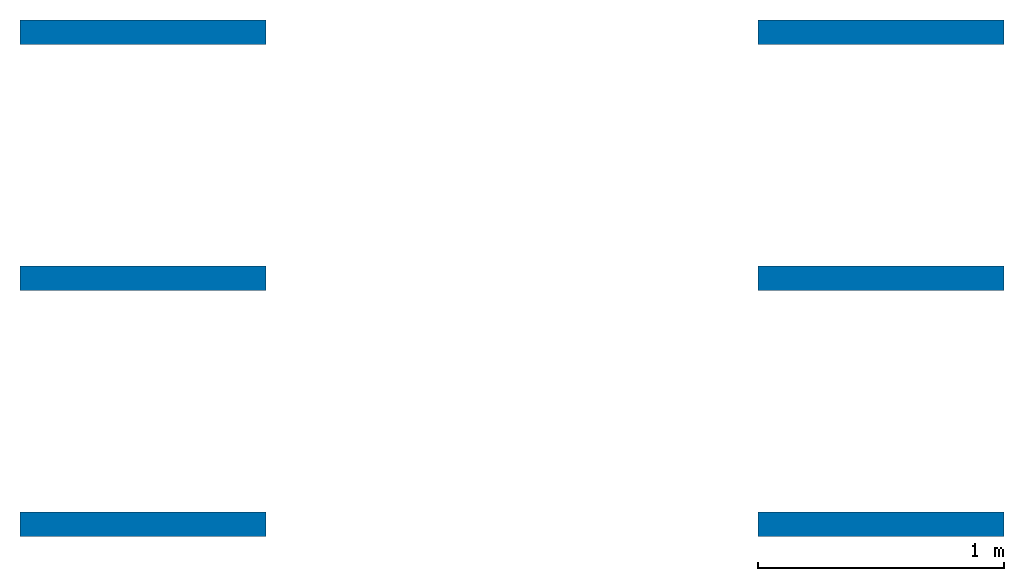
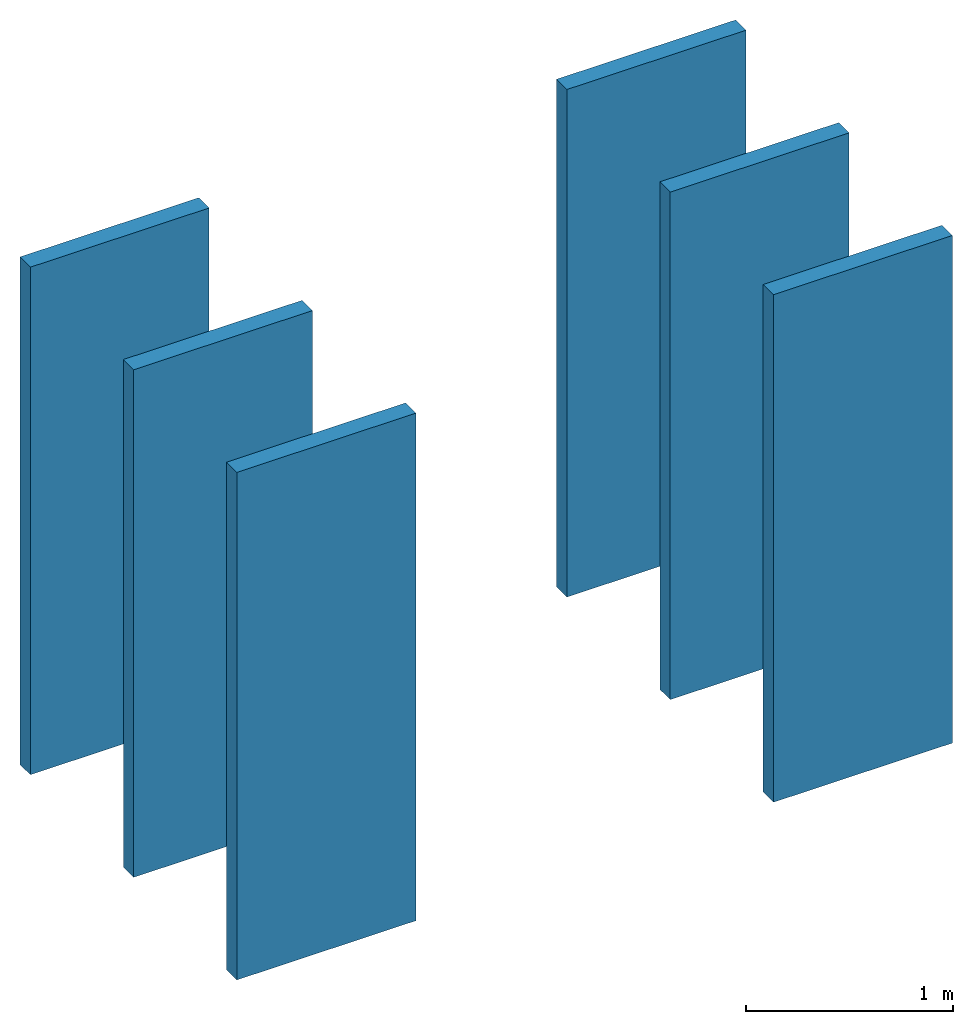
# One storey: 6 walls.
"""IFC4 building model written with IfcOpenShell, lengths in metres."""

import ifcopenshell
import ifcopenshell.guid

model = None  # the IFC model being written
_history = None  # IfcOwnerHistory: only IFC2X3 demands one
_inside = {}  # id of a spatial element -> (the spatial element, [elements in it])
_under = {}  # id of a project, library or spatial element -> (it, [spatial elements below it])
_declared = {}  # id of a project -> (the project, [libraries it declares])
_typed = {}  # id of a type object -> (the type object, [elements of that type])
_made_of = {}  # id of a material, layer set ... -> (it, [elements and type objects made of it])


def new_model(schema):
    """Start an empty IFC model of exactly this schema.

    Asked for "IFC4X3", IfcOpenShell would pick the latest addendum, in which some entities
    have other attributes; the version numbers below select the first issue.
    IFC2X3 requires an IfcOwnerHistory on every rooted entity: one is made here for all.
    """
    global model, _history
    if schema == "IFC4X3":
        model = ifcopenshell.file(schema_version=(4, 3, 0, 0))
    else:
        model = ifcopenshell.file(schema=schema)
    _inside.clear()
    _under.clear()
    _declared.clear()
    _typed.clear()
    _made_of.clear()
    _history = None
    if model.schema == "IFC2X3":
        org = make("IfcOrganization", Name="unknown")
        user = make(
            "IfcPersonAndOrganization",
            ThePerson=make("IfcPerson", FamilyName="unknown"),
            TheOrganization=org,
        )
        app = make(
            "IfcApplication",
            ApplicationDeveloper=org,
            Version="unknown",
            ApplicationFullName="unknown",
            ApplicationIdentifier="unknown",
        )
        _history = make(
            "IfcOwnerHistory",
            OwningUser=user,
            OwningApplication=app,
            ChangeAction="ADDED",
            CreationDate=0,
        )
    return model


def make(cls, **values):
    """One entity of the class cls with the attributes given. An attribute that is None is left unset."""
    return model.create_entity(
        cls, **{name: value for name, value in values.items() if value is not None}
    )


def entity(cls, *values):
    """Any entity or typed value of the class cls, its attributes in the order of the schema. None: left unset."""
    e = model.create_entity(cls)
    for i, value in enumerate(values):
        if value is not None:
            e[i] = value
    return e


def rooted(cls, **values):
    """An entity with a GlobalId (a new one), such as an element, a storey or a relation."""
    return make(cls, GlobalId=ifcopenshell.guid.new(), OwnerHistory=_history, **values)


def si_unit(unit_type, name, prefix=None):
    """IfcSIUnit, for example si_unit("LENGTHUNIT", "METRE", prefix="MILLI")."""
    return make("IfcSIUnit", UnitType=unit_type, Prefix=prefix, Name=name)


def converted_unit(unit_type, name, factor, base, dimensions=None, offset=None):
    """IfcConversionBasedUnit, such as the inch: factor (a typed value) times the base unit."""
    return make(
        "IfcConversionBasedUnit"
        if offset is None
        else "IfcConversionBasedUnitWithOffset",
        ConversionOffset=offset,
        Dimensions=None
        if dimensions is None
        else entity("IfcDimensionalExponents", *dimensions),
        UnitType=unit_type,
        Name=name,
        ConversionFactor=make(
            "IfcMeasureWithUnit", ValueComponent=factor, UnitComponent=base
        ),
    )


def assignment(units):
    """IfcUnitAssignment: the units of a project."""
    return None if units is None else make("IfcUnitAssignment", Units=units)


def point(xyz):
    """IfcCartesianPoint."""
    return None if xyz is None else make("IfcCartesianPoint", Coordinates=xyz)


def direction(xyz):
    """IfcDirection."""
    return None if xyz is None else make("IfcDirection", DirectionRatios=xyz)


def frame(location, z_axis=None, x_axis=None):
    """IfcAxis2Placement3D, a coordinate frame: its origin and axes. An axis left out is left unset."""
    return make(
        "IfcAxis2Placement3D",
        Location=point(location),
        Axis=direction(z_axis),
        RefDirection=direction(x_axis),
    )


def frame_2d(location, x_axis=None):
    """IfcAxis2Placement2D, a coordinate frame in the plane: its origin and x axis."""
    return make(
        "IfcAxis2Placement2D", Location=point(location), RefDirection=direction(x_axis)
    )


def origin_with_axes():
    """The frame at (0, 0, 0) with the z axis (0, 0, 1) and the x axis (1, 0, 0) written out."""
    return frame((0.0, 0.0, 0.0), z_axis=(0.0, 0.0, 1.0), x_axis=(1.0, 0.0, 0.0))


def origin_2d_with_axis():
    """The frame at (0, 0) in the plane with the x axis (1, 0) written out."""
    return frame_2d((0.0, 0.0), x_axis=(1.0, 0.0))


def place(relative_to, where):
    """IfcLocalPlacement: puts the frame where relative to a parent placement (None: the world)."""
    return make(
        "IfcLocalPlacement", PlacementRelTo=relative_to, RelativePlacement=where
    )


def context(
    kind, dimensions, precision=None, world=None, true_north=None, identifier=None
):
    """IfcGeometricRepresentationContext, for example the 3D "Model" context."""
    return make(
        "IfcGeometricRepresentationContext",
        ContextIdentifier=identifier,
        ContextType=kind,
        CoordinateSpaceDimension=dimensions,
        Precision=precision,
        WorldCoordinateSystem=world,
        TrueNorth=true_north,
    )


def subcontext(parent, identifier, kind, view, scale=None):
    """IfcGeometricRepresentationSubContext, for example "Body" below "Model"."""
    return make(
        "IfcGeometricRepresentationSubContext",
        ContextIdentifier=identifier,
        ContextType=kind,
        ParentContext=parent,
        TargetScale=scale,
        TargetView=view,
    )


def project(units=None, contexts=None):
    """IfcProject with its units and contexts."""
    return rooted(
        "IfcProject",
        Name="project",
        RepresentationContexts=contexts,
        UnitsInContext=assignment(units),
    )


def spatial(cls, under=None, at=None, **own):
    """A site, building, storey or space (cls), placed at a placement, below another one or the project."""
    s = rooted(cls, ObjectPlacement=at, **own)
    if under is not None:
        _under.setdefault(under.id(), (under, []))[1].append(s)
    return s


def point_list(points):
    """IfcCartesianPointList2D or 3D."""
    cls = (
        "IfcCartesianPointList2D" if len(points[0]) == 2 else "IfcCartesianPointList3D"
    )
    return make(cls, CoordList=points)


def indexed_curve(points, segments=None, self_intersect=None):
    """IfcIndexedPolyCurve: lines and arcs through numbered points (the first is 1)."""
    return make(
        "IfcIndexedPolyCurve",
        Points=point_list(points),
        Segments=segments,
        SelfIntersect=self_intersect,
    )


def outline(outer, holes=None, kind="AREA"):
    """IfcArbitraryClosedProfileDef: a profile drawn as a closed curve; with holes, ...WithVoids."""
    if holes is None:
        return make("IfcArbitraryClosedProfileDef", ProfileType=kind, OuterCurve=outer)
    return make(
        "IfcArbitraryProfileDefWithVoids",
        ProfileType=kind,
        OuterCurve=outer,
        InnerCurves=holes,
    )


def extrude(swept, where, along, depth):
    """IfcExtrudedAreaSolid: the profile swept, set in the frame where, extruded along a direction by depth."""
    return make(
        "IfcExtrudedAreaSolid",
        SweptArea=swept,
        Position=where,
        ExtrudedDirection=direction(along),
        Depth=depth,
    )


def shape(context_of_items, identifier, shape_type, items):
    """IfcShapeRepresentation: the items that make up one representation, for example the "Body"."""
    return make(
        "IfcShapeRepresentation",
        ContextOfItems=context_of_items,
        RepresentationIdentifier=identifier,
        RepresentationType=shape_type,
        Items=items,
    )


def material(Name=None, Category=None):
    """IfcMaterial."""
    return make("IfcMaterial", Name=Name, Category=Category)


def layer(
    of_material, thickness, ventilated=None, Name=None, Category=None, Priority=None
):
    """IfcMaterialLayer: one layer of a wall or slab, of a material (None: an air gap)."""
    return make(
        "IfcMaterialLayer",
        Material=of_material,
        LayerThickness=thickness,
        IsVentilated=ventilated,
        Name=Name,
        Category=Category,
        Priority=Priority,
    )


def layer_set(layers, Name=None):
    """IfcMaterialLayerSet."""
    return make("IfcMaterialLayerSet", MaterialLayers=layers, LayerSetName=Name)


def layer_usage(for_layer_set, set_direction, sense, offset, extent=None):
    """IfcMaterialLayerSetUsage: how a layer set lies in its element."""
    return make(
        "IfcMaterialLayerSetUsage",
        ForLayerSet=for_layer_set,
        LayerSetDirection=set_direction,
        DirectionSense=sense,
        OffsetFromReferenceLine=offset,
        ReferenceExtent=extent,
    )


def made_of(thing, what):
    """Note that an element or type object is made of a material, layer set ...; save() writes the relation."""
    if what is not None:
        _made_of.setdefault(what.id(), (what, []))[1].append(thing)
    return thing


def type_object(cls, material=None, **own):
    """A type object (cls), such as IfcWallType, which elements share."""
    return made_of(rooted(cls, **own), material)


def element(
    cls,
    number,
    at=None,
    inside=None,
    cuts=None,
    type_object=None,
    material=None,
    context=None,
    identifier="Body",
    shape_type=None,
    held_by="IfcProductDefinitionShape",
    body=None,
    shapes=None,
    **own,
):
    """One element of the class cls, such as IfcWall. Its Tag is "e" and its number.

    at: its placement. inside: the storey or other place that contains it. cuts: it is an
    opening in that element (IfcRelVoidsElement). A single representation is given by context,
    identifier, shape_type and body (its items); several are given by shapes. held_by: the class
    of the entity that holds the representations. save() writes the other relations.
    """
    e = rooted(cls, Tag="e%d" % number, ObjectPlacement=at, **own)
    if body is not None:
        shapes = [shape(context, identifier, shape_type, body)]
    if shapes is not None:
        e.Representation = make(held_by, Representations=shapes)
    if inside is not None:
        _inside.setdefault(inside.id(), (inside, []))[1].append(e)
    if cuts is not None:
        rooted(
            "IfcRelVoidsElement", RelatingBuildingElement=cuts, RelatedOpeningElement=e
        )
    if type_object is not None:
        _typed.setdefault(type_object.id(), (type_object, []))[1].append(e)
    return made_of(e, material)


def aggregate(whole, parts):
    """IfcRelAggregates: a whole, such as a stair, and the parts it consists of."""
    return rooted("IfcRelAggregates", RelatingObject=whole, RelatedObjects=parts)


def save(model, path):
    """Write the relations noted so far, then the file.

    IfcRelAggregates (storeys below a building ...), IfcRelContainedInSpatialStructure (elements
    in a storey), IfcRelDefinesByType, IfcRelAssociatesMaterial and IfcRelDeclares: one each for
    every whole, place, type object, material and project.
    """
    for whole, parts in _under.values():
        aggregate(whole, parts)
    for where, things in _inside.values():
        rooted(
            "IfcRelContainedInSpatialStructure",
            RelatedElements=things,
            RelatingStructure=where,
        )
    for kind, things in _typed.values():
        rooted("IfcRelDefinesByType", RelatedObjects=things, RelatingType=kind)
    for what, things in _made_of.values():
        rooted("IfcRelAssociatesMaterial", RelatedObjects=things, RelatingMaterial=what)
    for by, libraries in _declared.values():
        rooted("IfcRelDeclares", RelatingContext=by, RelatedDefinitions=libraries)
    model.write(path)


model = new_model("IFC4")

# Units and contexts
model_context = context("Model", 3, precision=1e-05, world=origin_with_axes())
plan_context = context("Plan", 2, precision=1e-05, world=origin_2d_with_axis())
body_context = subcontext(model_context, "Body", "Model", "MODEL_VIEW")
ifc_project = project(units=[si_unit("LENGTHUNIT", "METRE"), converted_unit("PLANEANGLEUNIT", "degree", entity("IfcReal", 0.0174532925199433), si_unit("PLANEANGLEUNIT", "RADIAN"), dimensions=[0, 0, 0, 0, 0, 0, 0]), si_unit("AREAUNIT", "SQUARE_METRE"), si_unit("VOLUMEUNIT", "CUBIC_METRE")], contexts=[model_context, plan_context])

# Site, building, storey
site_placement = place(None, origin_with_axes())
site = spatial("IfcSite", under=ifc_project, at=site_placement)
building_placement = place(site_placement, origin_with_axes())
building = spatial("IfcBuilding", under=site, at=building_placement, Name="Building")
storey_placement = place(building_placement, origin_with_axes())
storey = spatial("IfcBuildingStorey", under=building, at=storey_placement, Name="Storey")

# Walls
ifc_material = material()
ifc_layer_1 = layer(ifc_material, 0.1)
ifc_layer_set_1 = layer_set([ifc_layer_1], Name="concrete")
ifc_layer_usage_1 = layer_usage(ifc_layer_set_1, "AXIS2", "POSITIVE", 0.0)
wall_type_1 = type_object("IfcWallType", Name="WAL100_CONCRETE", PredefinedType="NOTDEFINED", material=ifc_layer_set_1)
wall_1_placement = place(storey_placement, origin_with_axes())
element("IfcWall", 1, at=wall_1_placement, inside=storey, type_object=wall_type_1, material=ifc_layer_usage_1, Name="Wall", context=body_context, shape_type="SweptSolid", body=[
    extrude(outline(indexed_curve([(0.0, 0.0), (0.0, 0.1), (1.0, 0.1), (1.0, 0.0), (0.0, 0.0)], self_intersect=False)), origin_with_axes(), (0.0, 0.0, 1.0), 3.0),
])
ifc_layer_usage_2 = layer_usage(ifc_layer_set_1, "AXIS2", "POSITIVE", 0.0)
wall_2_placement = place(storey_placement, frame((0.0, 1.0, 0.0), z_axis=(0.0, 0.0, 1.0), x_axis=(1.0, 0.0, 0.0)))
element("IfcWall", 2, at=wall_2_placement, inside=storey, type_object=wall_type_1, material=ifc_layer_usage_2, Name="Wall", context=body_context, shape_type="SweptSolid", body=[
    extrude(outline(indexed_curve([(0.0, 0.0), (0.0, 0.1), (1.0, 0.1), (1.0, 0.0), (0.0, 0.0)], self_intersect=False)), origin_with_axes(), (0.0, 0.0, 1.0), 3.0),
])
ifc_layer_usage_3 = layer_usage(ifc_layer_set_1, "AXIS2", "POSITIVE", 0.0)
wall_3_placement = place(storey_placement, frame((0.0, 2.0, 0.0), z_axis=(0.0, 0.0, 1.0), x_axis=(1.0, 0.0, 0.0)))
element("IfcWall", 3, at=wall_3_placement, inside=storey, type_object=wall_type_1, material=ifc_layer_usage_3, Name="Wall", context=body_context, shape_type="SweptSolid", body=[
    extrude(outline(indexed_curve([(0.0, 0.0), (0.0, 0.1), (1.0, 0.1), (1.0, 0.0), (0.0, 0.0)], self_intersect=False)), origin_with_axes(), (0.0, 0.0, 1.0), 3.0),
])
ifc_layer_2 = layer(ifc_material, 0.1)
ifc_layer_set_2 = layer_set([ifc_layer_2], Name="brick")
ifc_layer_usage_4 = layer_usage(ifc_layer_set_2, "AXIS2", "POSITIVE", 0.0)
wall_type_2 = type_object("IfcWallType", Name="WAL100_BRICK", PredefinedType="NOTDEFINED", material=ifc_layer_set_2)
wall_4_placement = place(storey_placement, frame((3.0, 0.0, 0.0), z_axis=(0.0, 0.0, 1.0), x_axis=(1.0, 0.0, 0.0)))
element("IfcWall", 4, at=wall_4_placement, inside=storey, type_object=wall_type_2, material=ifc_layer_usage_4, Name="Wall", context=body_context, shape_type="SweptSolid", body=[
    extrude(outline(indexed_curve([(0.0, 0.0), (0.0, 0.1), (1.0, 0.1), (1.0, 0.0), (0.0, 0.0)], self_intersect=False)), origin_with_axes(), (0.0, 0.0, 1.0), 3.0),
])
ifc_layer_usage_5 = layer_usage(ifc_layer_set_2, "AXIS2", "POSITIVE", 0.0)
wall_5_placement = place(storey_placement, frame((3.0, 1.0, 0.0), z_axis=(0.0, 0.0, 1.0), x_axis=(1.0, 0.0, 0.0)))
element("IfcWall", 5, at=wall_5_placement, inside=storey, type_object=wall_type_2, material=ifc_layer_usage_5, Name="Wall", context=body_context, shape_type="SweptSolid", body=[
    extrude(outline(indexed_curve([(0.0, 0.0), (0.0, 0.1), (1.0, 0.1), (1.0, 0.0), (0.0, 0.0)], self_intersect=False)), origin_with_axes(), (0.0, 0.0, 1.0), 3.0),
])
ifc_layer_usage_6 = layer_usage(ifc_layer_set_2, "AXIS2", "POSITIVE", 0.0)
wall_6_placement = place(storey_placement, frame((3.0, 2.0, 0.0), z_axis=(0.0, 0.0, 1.0), x_axis=(1.0, 0.0, 0.0)))
element("IfcWall", 6, at=wall_6_placement, inside=storey, type_object=wall_type_2, material=ifc_layer_usage_6, Name="Wall", context=body_context, shape_type="SweptSolid", body=[
    extrude(outline(indexed_curve([(0.0, 0.0), (0.0, 0.1), (1.0, 0.1), (1.0, 0.0), (0.0, 0.0)], self_intersect=False)), origin_with_axes(), (0.0, 0.0, 1.0), 3.0),
])

save(model, "model.ifc")
